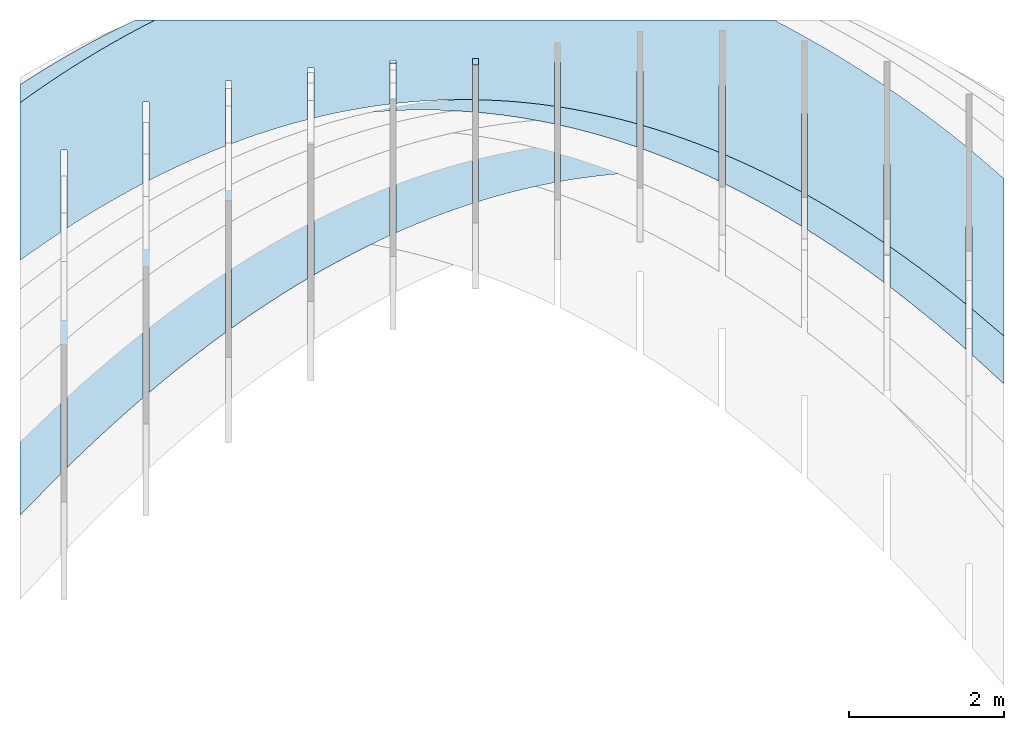
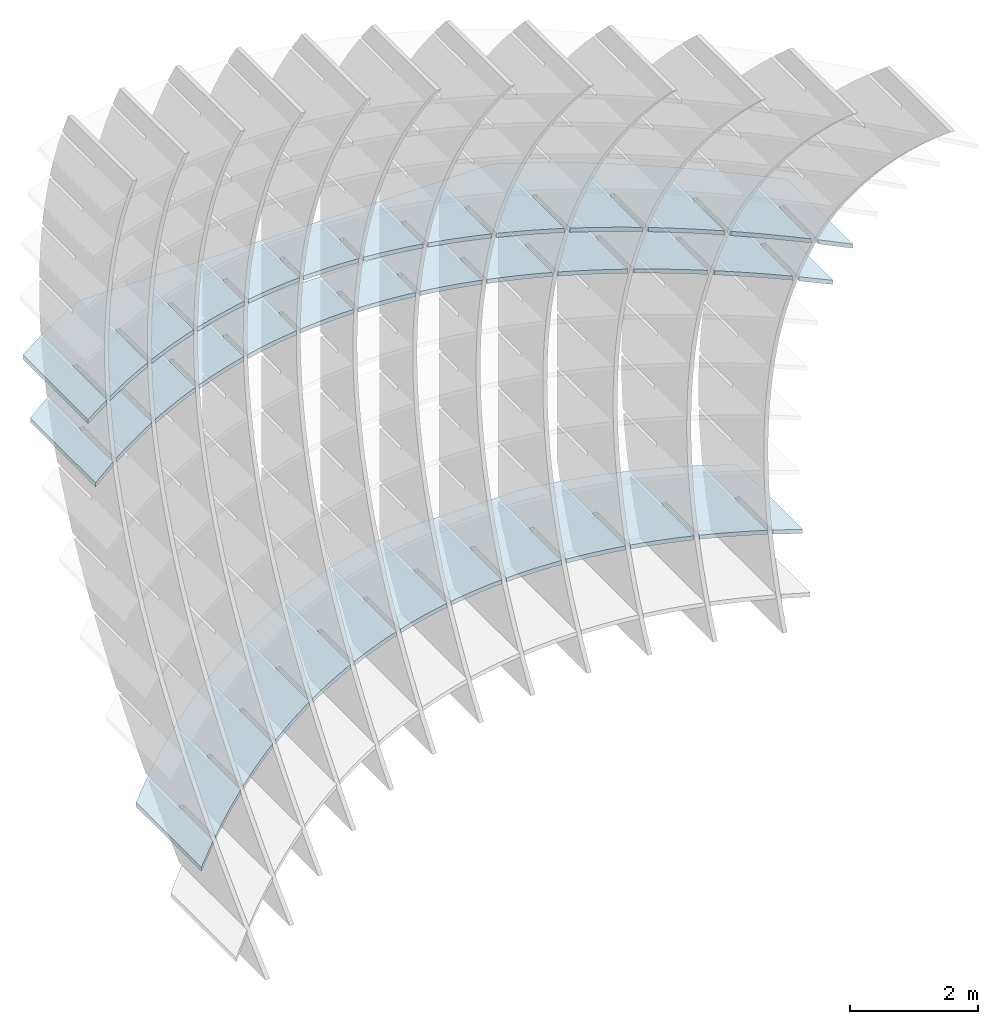
# Not in any storey, part 3 of 9: 3 slabs.
"""IFC2X3 building model written with IfcOpenShell, lengths in metres."""

from ifc_helpers import new_model, si_unit, point, direction, frame, frame_2d, origin_with_axes, place, context, project, spatial, polyline, circle_curve, parameter, trimmed, segment, composite_curve, outline, extrude, material, layer, layer_set, layer_usage, type_object, element, save


model = new_model("IFC2X3")

# Units and contexts
model_context = context("Model", 3, precision=2.54e-06, world=origin_with_axes(), true_north=direction((0.0, 1.0)), identifier="Body")
ifc_project = project(units=[si_unit("LENGTHUNIT", "METRE"), si_unit("AREAUNIT", "SQUARE_METRE"), si_unit("VOLUMEUNIT", "CUBIC_METRE"), si_unit("PLANEANGLEUNIT", "RADIAN")], contexts=[model_context])

# Building
building_placement = place(None, origin_with_axes())
building = spatial("IfcBuilding", under=ifc_project, at=building_placement, Name="Building", CompositionType="ELEMENT")

# Slabs
ifc_material = material(Name="MATERIAL")
ifc_layer = layer(ifc_material, 0.07874, ventilated=True)
ifc_layer_set = layer_set([ifc_layer], Name="SLAB")
ifc_layer_usage_1 = layer_usage(ifc_layer_set, "AXIS3", "NEGATIVE", -0.07874)
slab_type = type_object("IfcSlabType", Name="SLAB", PredefinedType="FLOOR", material=ifc_material)
slab_1_placement = place(None, frame((6.71456553163902, -0.108020556444148, 1.44983825891174), z_axis=(0.0, 0.0, 1.0), x_axis=(-0.85002223, -0.52674681, 0.0)))
element("IfcSlab", 1, at=slab_1_placement, inside=building, type_object=slab_type, material=ifc_layer_usage_1, PredefinedType="FLOOR", context=model_context, shape_type="SweptSolid", body=[
    extrude(outline(composite_curve([segment(polyline([(0.0, 0.0), (0.619943851972478, 0.0)]), True, "CONTINUOUS"), segment(polyline([(0.619943851972478, 0.0), (-0.45040566483358, -1.72724518001152)]), True, "CONTINUOUS"), segment(trimmed(circle_curve(frame_2d((-0.780572223311812, 10.3688137838267), x_axis=(-0.11368899, -0.99351639)), 12.1005641361463), [parameter(0.141223936628406), point((-0.45040566483358, -1.72724518001152))], [parameter(0.0), point((-2.15627308445549, -1.65329499764907))], False, "PARAMETER"), True, "CONTINUOUS"), segment(polyline([(-2.15627308445549, -1.65329499764907), (-8.47655792243422, 2.26329652085337)]), True, "CONTINUOUS"), segment(trimmed(circle_curve(frame_2d((1.82307330734841, 8.92364200892579), x_axis=(-0.91794493, -0.39670784)), 12.2655046977285), [parameter(0.166095085931435), point((-8.47655792243422, 2.26329652085337))], [parameter(0.0), point((-9.43598450566048, 4.05782012014648))], False, "PARAMETER"), True, "CONTINUOUS"), segment(trimmed(circle_curve(frame_2d((6.27845292191441, 10.8391995223138), x_axis=(-0.96759334, -0.25251363)), 17.115216921246), [parameter(0.152118271695288), point((-9.43598450566048, 4.05782012014648))], [parameter(0.0), point((-10.2821169341494, 6.51737394696515))], False, "PARAMETER"), True, "CONTINUOUS"), segment(polyline([(-10.2821169341494, 6.51737394696515), (-9.21176741734327, 8.2446191269766)]), True, "CONTINUOUS"), segment(polyline([(-9.21176741734327, 8.2446191269766), (-9.06056282598788, 7.70970050535006)]), True, "CONTINUOUS"), segment(polyline([(-9.06056282598788, 7.70970050535006), (-9.62423124892391, 6.80009709884209)]), True, "CONTINUOUS"), segment(polyline([(-9.62423124892391, 6.80009709884209), (-9.55730049819846, 6.75862105506585)]), True, "CONTINUOUS"), segment(polyline([(-9.55730049819846, 6.75862105506585), (-9.03044741616067, 7.60881478359619)]), True, "CONTINUOUS"), segment(trimmed(circle_curve(frame_2d((7.26166612219884, 12.4941266221262), x_axis=(-0.95786385, -0.28722263)), 17.0087987614199), [parameter(0.0), point((-9.03044741616067, 7.60881478359619))], [parameter(0.0748195872683051), point((-8.61969121322019, 6.40465008541053))], True, "PARAMETER"), True, "CONTINUOUS"), segment(polyline([(-8.61969121322019, 6.40465008541053), (-9.18057947132105, 5.49953308846976)]), True, "CONTINUOUS"), segment(polyline([(-9.18057947132105, 5.49953308846976), (-9.1136487205956, 5.45805704469352)]), True, "CONTINUOUS"), segment(polyline([(-9.1136487205956, 5.45805704469352), (-8.58401554786144, 6.31273706315057)]), True, "CONTINUOUS"), segment(trimmed(circle_curve(frame_2d((4.61745272777462, 11.4666730631361), x_axis=(-0.93152639, -0.36367374)), 14.1718672349332), [parameter(0.0), point((-8.58401554786144, 6.31273706315057))], [parameter(0.0842035553852768), point((-8.10377533227857, 5.22070015503865))], True, "PARAMETER"), True, "CONTINUOUS"), segment(polyline([(-8.10377533227857, 5.22070015503865), (-8.6618884659955, 4.32006143378192)]), True, "CONTINUOUS"), segment(polyline([(-8.6618884659955, 4.32006143378192), (-8.59495771527005, 4.27858539000569)]), True, "CONTINUOUS"), segment(polyline([(-8.59495771527005, 4.27858539000569), (-8.06254941815232, 5.13774368414764)]), True, "CONTINUOUS"), segment(trimmed(circle_curve(frame_2d((2.53365823412119, 10.4346601334395), x_axis=(-0.89446728, -0.44713341)), 11.8463893436303), [parameter(0.0), point((-8.06254941815232, 5.13774368414764))], [parameter(0.094893498567618), point((-7.5129880604681, 4.15757173894531))], True, "PARAMETER"), True, "CONTINUOUS"), segment(polyline([(-7.5129880604681, 4.15757173894531), (-8.06832607016689, 3.26141129278416)]), True, "CONTINUOUS"), segment(polyline([(-8.06832607016689, 3.26141129278416), (-8.00139531944145, 3.21993524900793)]), True, "CONTINUOUS"), segment(polyline([(-8.00139531944145, 3.21993524900793), (-7.46621189757592, 4.08357181942253)]), True, "CONTINUOUS"), segment(trimmed(circle_curve(frame_2d((1.07524938924406, 9.51675930543096), x_axis=(-0.84376384, -0.53671462)), 10.1230473263915), [parameter(0.0), point((-7.46621189757592, 4.08357181942253))], [parameter(0.105381578815588), point((-6.84732939741331, 3.21526483653157))], True, "PARAMETER"), True, "CONTINUOUS"), segment(polyline([(-6.84732939741331, 3.21526483653157), (-7.3001856311673, 2.48448135439944)]), True, "CONTINUOUS"), segment(polyline([(-7.3001856311673, 2.48448135439944), (-7.23325488044185, 2.4430053106232)]), True, "CONTINUOUS"), segment(polyline([(-7.23325488044185, 2.4430053106232), (-6.79500298575276, 3.15022146838022)]), True, "CONTINUOUS"), segment(trimmed(circle_curve(frame_2d((0.145217501277417, 8.77308549960715), x_axis=(-0.77699349, -0.62950864)), 8.93214757615765), [parameter(0.0), point((-6.79500298575276, 3.15022146838022))], [parameter(0.114554431580325), point((-6.10679934349017, 2.3937794483974))], True, "PARAMETER"), True, "CONTINUOUS"), segment(polyline([(-6.10679934349017, 2.3937794483974), (-6.47709396087449, 1.79622735628225)]), True, "CONTINUOUS"), segment(polyline([(-6.47709396087449, 1.79622735628225), (-6.41016321014904, 1.75475131250601)]), True, "CONTINUOUS"), segment(polyline([(-6.41016321014904, 1.75475131250601), (-6.04892268306232, 2.33769263161573)]), True, "CONTINUOUS"), segment(trimmed(circle_curve(frame_2d((-0.353446121629419, 8.26375363661473), x_axis=(-0.6929406, -0.72099468)), 8.21928538845084), [parameter(0.0), point((-6.04892268306232, 2.33769263161573))], [parameter(0.121087811880618), point((-5.29139789857281, 1.69311557434231))], True, "PARAMETER"), True, "CONTINUOUS"), segment(polyline([(-5.29139789857281, 1.69311557434231), (-5.6165665950848, 1.1683841152048)]), True, "CONTINUOUS"), segment(polyline([(-5.6165665950848, 1.1683841152048), (-5.54963584435935, 1.12690807142857)]), True, "CONTINUOUS"), segment(polyline([(-5.54963584435935, 1.12690807142857), (-5.22797098937811, 1.64598530893072)]), True, "CONTINUOUS"), segment(trimmed(circle_curve(frame_2d((-0.517750171626338, 8.0488786368442), x_axis=(-0.59257098, -0.80551824)), 7.94878752519031), [parameter(0.0), point((-5.22797098937811, 1.64598530893072))], [parameter(0.123820419877384), point((-4.40112506266206, 1.11327321436705))], True, "PARAMETER"), True, "CONTINUOUS"), segment(polyline([(-4.40112506266206, 1.11327321436705), (-4.71860353379821, 0.600951631167097)]), True, "CONTINUOUS"), segment(polyline([(-4.71860353379821, 0.600951631167097), (-4.65167278307277, 0.559475587390863)]), True, "CONTINUOUS"), segment(polyline([(-4.65167278307277, 0.559475587390863), (-4.33214790470012, 1.0750995003252)]), True, "CONTINUOUS"), segment(trimmed(circle_curve(frame_2d((-0.444703340745303, 8.1885754207733), x_axis=(-0.47955236, -0.87751327)), 8.10640271073531), [parameter(0.0), point((-4.33214790470012, 1.0750995003252))], [parameter(0.122209681178168), point((-3.43598083575751, 0.654252368471235))], True, "PARAMETER"), True, "CONTINUOUS"), segment(polyline([(-3.43598083575751, 0.654252368471235), (-3.78320477701475, 0.0939299041691344)]), True, "CONTINUOUS"), segment(polyline([(-3.78320477701475, 0.0939299041691344), (-3.7162740262893, 0.0524538603928997)]), True, "CONTINUOUS"), segment(polyline([(-3.7162740262893, 0.0524538603928997), (-3.36145342902837, 0.625035205799166)]), True, "CONTINUOUS"), segment(trimmed(circle_curve(frame_2d((-0.231314321018002, 8.74295890888007), x_axis=(-0.35976601, -0.93304256)), 8.70048596829733), [parameter(0.0), point((-3.36145342902837, 0.625035205799166))], [parameter(0.116579560971218), point((-2.39596521785895, 0.316053036654818))], True, "PARAMETER"), True, "CONTINUOUS"), segment(polyline([(-2.39596521785895, 0.316053036654818), (-2.8103703247344, -0.352681065789085)]), True, "CONTINUOUS"), segment(polyline([(-2.8103703247344, -0.352681065789085), (-2.74343957400895, -0.39415710956532)]), True, "CONTINUOUS"), segment(polyline([(-2.74343957400895, -0.39415710956532), (-2.31588756236284, 0.295792425352612)]), True, "CONTINUOUS"), segment(trimmed(circle_curve(frame_2d((0.0254081955237848, 9.77214402164274), x_axis=(-0.239855, -0.97080872)), 9.76129629723473), [parameter(0.0), point((-2.31588756236284, 0.295792425352612))], [parameter(0.107970086288465), point((-1.28107820896716, 0.0986752189180085))], True, "PARAMETER"), True, "CONTINUOUS"), segment(polyline([(-1.28107820896716, 0.0986752189180085), (-1.80010017695716, -0.738881278707563)]), True, "CONTINUOUS"), segment(polyline([(-1.80010017695716, -0.738881278707563), (-1.73316942623171, -0.780357322483799)]), True, "CONTINUOUS"), segment(polyline([(-1.73316942623171, -0.780357322483799), (-1.19545030470354, 0.0873711589855444)]), True, "CONTINUOUS"), segment(trimmed(circle_curve(frame_2d((0.22369431064194, 11.289366152602), x_axis=(-0.12568222, -0.99207055)), 11.2915305993595), [parameter(0.0), point((-1.19545030470354, 0.0873711589855444))], [parameter(0.0981196132915255), point((-0.0912517868518765, 0.00222868414058078))], True, "PARAMETER"), True, "CONTINUOUS"), segment(polyline([(-0.0912517868518765, 0.00222868414058078), (-0.624350236750215, -0.858043323835378)]), True, "CONTINUOUS"), segment(polyline([(-0.624350236750215, -0.858043323835378), (-0.557419486024768, -0.899519367611613)]), True, "CONTINUOUS"), segment(polyline([(-0.557419486024768, -0.899519367611613), (0.0, 0.0)]), True, "CONTINUOUS")], self_intersect="UNKNOWN")), origin_with_axes(), (0.0, 0.0, 1.0), 0.07874),
])
ifc_layer_usage_2 = layer_usage(ifc_layer_set, "AXIS3", "NEGATIVE", -0.07874)
slab_2_placement = place(None, frame((6.71456553163902, -0.305201526189746, 0.38765644072992), z_axis=(0.0, 0.0, 1.0), x_axis=(-0.82439006, -0.5660221, 0.0)))
element("IfcSlab", 2, at=slab_2_placement, inside=building, type_object=slab_type, material=ifc_layer_usage_2, PredefinedType="FLOOR", context=model_context, shape_type="SweptSolid", body=[
    extrude(outline(composite_curve([segment(polyline([(0.0, 0.0), (0.639219322500902, 0.0)]), True, "CONTINUOUS"), segment(polyline([(0.639219322500902, 0.0), (-0.51093759320319, -1.6751606099888)]), True, "CONTINUOUS"), segment(trimmed(circle_curve(frame_2d((-0.860880402843568, 11.1969275062184), x_axis=(-0.13147961, -0.99131887)), 12.8768440404247), [parameter(0.159040880589641), point((-0.51093759320319, -1.6751606099888))], [parameter(0.0), point((-2.55392287277681, -1.56813103796478))], False, "PARAMETER"), True, "CONTINUOUS"), segment(polyline([(-2.55392287277681, -1.56813103796478), (-9.13748298390622, 2.9521084821252)]), True, "CONTINUOUS"), segment(trimmed(circle_curve(frame_2d((3.3894060369244, 9.67536672278256), x_axis=(-0.97176513, -0.23595028)), 14.2170724803236), [parameter(0.254383189270301), point((-9.13748298390622, 2.9521084821252))], [parameter(0.0), point((-10.4262492228901, 6.32084445385438))], False, "PARAMETER"), True, "CONTINUOUS"), segment(polyline([(-10.4262492228901, 6.32084445385438), (-9.27609230718604, 7.99600506384352)]), True, "CONTINUOUS"), segment(polyline([(-9.27609230718604, 7.99600506384352), (-9.1345958273157, 7.47721675580939)]), True, "CONTINUOUS"), segment(polyline([(-9.1345958273157, 7.47721675580939), (-9.7388014726668, 6.59721378960071)]), True, "CONTINUOUS"), segment(polyline([(-9.7388014726668, 6.59721378960071), (-9.67388899902974, 6.55264520911718)]), True, "CONTINUOUS"), segment(polyline([(-9.67388899902974, 6.55264520911718), (-9.10626167676065, 7.37937321330129)]), True, "CONTINUOUS"), segment(trimmed(circle_curve(frame_2d((5.70841080382251, 11.6910937403307), x_axis=(-0.96016056, -0.27944891)), 15.4293698708066), [parameter(0.0), point((-9.10626167676065, 7.37937321330129))], [parameter(0.0798428635516468), point((-8.71517139560407, 6.21151974716851))], True, "PARAMETER"), True, "CONTINUOUS"), segment(polyline([(-8.71517139560407, 6.21151974716851), (-9.31638958147367, 5.33586790416582)]), True, "CONTINUOUS"), segment(polyline([(-9.31638958147367, 5.33586790416582), (-9.2514771078366, 5.29129932368229)]), True, "CONTINUOUS"), segment(polyline([(-9.2514771078366, 5.29129932368229), (-8.68086240575325, 6.12237833504081)]), True, "CONTINUOUS"), segment(trimmed(circle_curve(frame_2d((3.37531212291804, 10.7922639768272), x_axis=(-0.9324905, -0.3611945)), 12.9290052275163), [parameter(0.0), point((-8.68086240575325, 6.12237833504081))], [parameter(0.0895181356163792), point((-8.2151072451179, 5.06327147847268))], True, "PARAMETER"), True, "CONTINUOUS"), segment(polyline([(-8.2151072451179, 5.06327147847268), (-8.81334338778476, 4.19196287007089)]), True, "CONTINUOUS"), segment(polyline([(-8.81334338778476, 4.19196287007089), (-8.7484309141477, 4.14739428958736)]), True, "CONTINUOUS"), segment(polyline([(-8.7484309141477, 4.14739428958736), (-8.17483416886108, 4.9828165355456)]), True, "CONTINUOUS"), segment(trimmed(circle_curve(frame_2d((1.57220634854681, 9.8933455085617), x_axis=(-0.89306672, -0.44992426)), 10.9141235856491), [parameter(0.0), point((-8.17483416886108, 4.9828165355456))], [parameter(0.100224490194485), point((-7.63458914310767, 4.0322013866626))], True, "PARAMETER"), True, "CONTINUOUS"), segment(polyline([(-7.63458914310767, 4.0322013866626), (-8.14281575209515, 3.2919883038217)]), True, "CONTINUOUS"), segment(polyline([(-8.14281575209515, 3.2919883038217), (-8.07790327845808, 3.24741972333816)]), True, "CONTINUOUS"), segment(polyline([(-8.07790327845808, 3.24741972333816), (-7.58835198044396, 3.96043291293423)]), True, "CONTINUOUS"), segment(trimmed(circle_curve(frame_2d((0.352107047136366, 9.11139008078399), x_axis=(-0.83894252, -0.54422004)), 9.46484280448993), [parameter(0.0), point((-7.58835198044396, 3.96043291293423))], [parameter(0.110213642371295), point((-6.97361708957169, 3.11830947173511))], True, "PARAMETER"), True, "CONTINUOUS"), segment(polyline([(-6.97361708957169, 3.11830947173511), (-7.37301263520595, 2.53660476978088)]), True, "CONTINUOUS"), segment(polyline([(-7.37301263520595, 2.53660476978088), (-7.30810016156888, 2.49203618929734)]), True, "CONTINUOUS"), segment(polyline([(-7.30810016156888, 2.49203618929734), (-6.92141584050189, 3.05522746720671)]), True, "CONTINUOUS"), segment(trimmed(circle_curve(frame_2d((-0.379069204790771, 8.51099490257198), x_axis=(-0.76800116, -0.64044845)), 8.51866760770678), [parameter(0.0), point((-6.92141584050189, 3.05522746720671))], [parameter(0.118233031779908), point((-6.23219108451158, 2.32159573369248))], True, "PARAMETER"), True, "CONTINUOUS"), segment(polyline([(-6.23219108451158, 2.32159573369248), (-6.56298254255427, 1.83981032418197)]), True, "CONTINUOUS"), segment(polyline([(-6.56298254255427, 1.83981032418197), (-6.4980700689172, 1.79524174369844)]), True, "CONTINUOUS"), segment(polyline([(-6.4980700689172, 1.79524174369844), (-6.17402574903486, 2.26720019836303)]), True, "CONTINUOUS"), segment(trimmed(circle_curve(frame_2d((-0.715405830709196, 8.1567571830059), x_axis=(-0.67976508, -0.73342992)), 8.03015646722387), [parameter(0.0), point((-6.17402574903486, 2.26720019836303))], [parameter(0.122982293439983), point((-5.41031112792561, 1.64206017253285))], True, "PARAMETER"), True, "CONTINUOUS"), segment(polyline([(-5.41031112792561, 1.64206017253285), (-5.71272547414011, 1.20160496702499)]), True, "CONTINUOUS"), segment(polyline([(-5.71272547414011, 1.20160496702499), (-5.64781300050304, 1.15703638654146)]), True, "CONTINUOUS"), segment(polyline([(-5.64781300050304, 1.15703638654146), (-5.34618170604288, 1.5963511064032)]), True, "CONTINUOUS"), segment(trimmed(circle_curve(frame_2d((-0.750986254095934, 8.11327413116397), x_axis=(-0.57626583, -0.81726231)), 7.97408972562079), [parameter(0.0), point((-5.34618170604288, 1.5963511064032))], [parameter(0.123558271913986), point((-4.50797721981565, 1.07970278825777))], True, "PARAMETER"), True, "CONTINUOUS"), segment(polyline([(-4.50797721981565, 1.07970278825777), (-4.82224142996347, 0.621988698309929)]), True, "CONTINUOUS"), segment(polyline([(-4.82224142996347, 0.621988698309929), (-4.7573289563264, 0.577420117826396)]), True, "CONTINUOUS"), segment(polyline([(-4.7573289563264, 0.577420117826396), (-4.43788371152595, 1.04268019132721)]), True, "CONTINUOUS"), segment(trimmed(circle_curve(frame_2d((-0.579893898427181, 8.44514295612494), x_axis=(-0.4621738, -0.88678937)), 8.34748706990257), [parameter(0.0), point((-4.43788371152595, 1.04268019132721))], [parameter(0.119844445167166), point((-3.52518936018013, 0.63452358086614))], True, "PARAMETER"), True, "CONTINUOUS"), segment(polyline([(-3.52518936018013, 0.63452358086614), (-3.89153041002436, 0.100961518036794)]), True, "CONTINUOUS"), segment(polyline([(-3.89153041002436, 0.100961518036794), (-3.82661793638729, 0.0563929375532603)]), True, "CONTINUOUS"), segment(polyline([(-3.82661793638729, 0.0563929375532603), (-3.44913176548406, 0.606187453135067)]), True, "CONTINUOUS"), segment(trimmed(circle_curve(frame_2d((-0.296212187178691, 9.2169608669687), x_axis=(-0.34383511, -0.93903004)), 9.16985935833508), [parameter(0.0), point((-3.44913176548406, 0.606187453135067))], [parameter(0.112565458213441), point((-2.46194754902009, 0.306522550358507))], True, "PARAMETER"), True, "CONTINUOUS"), segment(polyline([(-2.46194754902009, 0.306522550358507), (-2.92059241432276, -0.361476573794421)]), True, "CONTINUOUS"), segment(polyline([(-2.92059241432276, -0.361476573794421), (-2.8556799406857, -0.406045154277955)]), True, "CONTINUOUS"), segment(polyline([(-2.8556799406857, -0.406045154277955), (-2.37992586791721, 0.286872891826767)]), True, "CONTINUOUS"), segment(trimmed(circle_curve(frame_2d((0.00597545649898953, 10.4933250744186), x_axis=(-0.22762733, -0.97374833)), 10.4816120556613), [parameter(0.0), point((-2.37992586791721, 0.286872891826767))], [parameter(0.102963694286493), point((-1.31825178385167, 0.0956996964153215))], True, "PARAMETER"), True, "CONTINUOUS"), segment(polyline([(-1.31825178385167, 0.0956996964153215), (-1.89263158413763, -0.740863039915794)]), True, "CONTINUOUS"), segment(polyline([(-1.89263158413763, -0.740863039915794), (-1.82771911050056, -0.785431620399328)]), True, "CONTINUOUS"), segment(polyline([(-1.82771911050056, -0.785431620399328), (-1.2302660163302, 0.0847365071012922)]), True, "CONTINUOUS"), segment(trimmed(circle_curve(frame_2d((0.227700576123366, 12.2878085829216), x_axis=(-0.11863168, -0.99293833)), 12.2898590175956), [parameter(0.0), point((-1.2302660163302, 0.0847365071012922))], [parameter(0.092730266045169), point((-0.0940289780220891, 0.0021614788262917))], True, "PARAMETER"), True, "CONTINUOUS"), segment(polyline([(-0.0940289780220891, 0.0021614788262917), (-0.665385292056546, -0.829997662653379)]), True, "CONTINUOUS"), segment(polyline([(-0.665385292056546, -0.829997662653379), (-0.600472818419479, -0.874566243136913)]), True, "CONTINUOUS"), segment(polyline([(-0.600472818419479, -0.874566243136913), (0.0, 0.0)]), True, "CONTINUOUS")], self_intersect="UNKNOWN")), origin_with_axes(), (0.0, 0.0, 1.0), 0.07874),
])
ifc_layer_usage_3 = layer_usage(ifc_layer_set, "AXIS3", "NEGATIVE", -0.07874)
slab_3_placement = place(None, frame((6.71456553163902, -3.42319496995906, -4.92325265017917), z_axis=(0.0, 0.0, 1.0), x_axis=(-0.6996724, -0.7144638, 0.0)))
element("IfcSlab", 3, at=slab_3_placement, inside=building, type_object=slab_type, material=ifc_layer_usage_3, PredefinedType="FLOOR", context=model_context, shape_type="SweptSolid", body=[
    extrude(outline(composite_curve([segment(polyline([(0.0, 0.0), (0.753161129482883, 0.0)]), True, "CONTINUOUS"), segment(polyline([(0.753161129482883, 0.0), (-0.698629319765602, -1.42173432520668)]), True, "CONTINUOUS"), segment(trimmed(circle_curve(frame_2d((-1.12790886808711, 18.8110326763434), x_axis=(-0.11480144, -0.99338846)), 20.2373205111156), [parameter(0.136268982861436), point((-0.698629319765602, -1.42173432520668))], [parameter(0.0), point((-3.45118248235088, -1.29248794027713))], False, "PARAMETER"), True, "CONTINUOUS"), segment(trimmed(circle_curve(frame_2d((-1.80699979804032, 12.8984882623517), x_axis=(-0.26255508, -0.96491701)), 14.2859071214594), [parameter(0.15032238882636), point((-3.45118248235088, -1.29248794027713))], [parameter(0.0), point((-5.55783729767384, -0.886226472974065))], False, "PARAMETER"), True, "CONTINUOUS"), segment(trimmed(circle_curve(frame_2d((-3.13709164146096, 8.40109302342931), x_axis=(-0.60364718, -0.79725158)), 9.59762017170651), [parameter(0.393090525130409), point((-5.55783729767384, -0.886226472974065))], [parameter(0.0), point((-8.93066796749937, 0.749375156524194))], False, "PARAMETER"), True, "CONTINUOUS"), segment(polyline([(-8.93066796749937, 0.749375156524194), (-10.4452230504127, 2.29594863741314)]), True, "CONTINUOUS"), segment(trimmed(circle_curve(frame_2d((-2.84599575259045, 7.83735161751861), x_axis=(-0.96481843, -0.26291711)), 9.40507323267014), [parameter(0.364015219483743), point((-10.4452230504127, 2.29594863741314))], [parameter(0.0), point((-11.9201837019689, 5.36459696506245))], False, "PARAMETER"), True, "CONTINUOUS"), segment(polyline([(-11.9201837019689, 5.36459696506245), (-10.4683932527203, 6.78633129026876)]), True, "CONTINUOUS"), segment(polyline([(-10.4683932527203, 6.78633129026876), (-10.3315963747117, 6.34602775122306)]), True, "CONTINUOUS"), segment(polyline([(-10.3315963747117, 6.34602775122306), (-11.084847273671, 5.60837125327763)]), True, "CONTINUOUS"), segment(polyline([(-11.084847273671, 5.60837125327763), (-11.0297550685693, 5.55211437336926)]), True, "CONTINUOUS"), segment(polyline([(-11.0297550685693, 5.55211437336926), (-10.3038548297345, 6.26298644637497)]), True, "CONTINUOUS"), segment(trimmed(circle_curve(frame_2d((-0.805191645483418, 9.45979317694922), x_axis=(-0.94776378, -0.31897306)), 10.0221841711521), [parameter(0.0), point((-10.3038548297345, 6.26298644637497))], [parameter(0.106455079224624), point((-9.91040907148871, 5.27181142129877))], True, "PARAMETER"), True, "CONTINUOUS"), segment(polyline([(-9.91040907148871, 5.27181142129877), (-10.6598890370358, 4.53784778789304)]), True, "CONTINUOUS"), segment(polyline([(-10.6598890370358, 4.53784778789304), (-10.604796831934, 4.48159090798466)]), True, "CONTINUOUS"), segment(polyline([(-10.604796831934, 4.48159090798466), (-9.87512576024723, 5.19615574705245)]), True, "CONTINUOUS"), segment(trimmed(circle_curve(frame_2d((-1.79311143997881, 8.9993524089713), x_axis=(-0.9048232, -0.42578749)), 8.9321475761574), [parameter(0.0), point((-9.87512576024723, 5.19615574705245))], [parameter(0.114554431580327), point((-9.38743394092832, 4.29727562590762))], True, "PARAMETER"), True, "CONTINUOUS"), segment(polyline([(-9.38743394092832, 4.29727562590762), (-10.1331498097836, 3.56699816186205)]), True, "CONTINUOUS"), segment(polyline([(-10.1331498097836, 3.56699816186205), (-10.0780576046819, 3.51074128195367)]), True, "CONTINUOUS"), segment(polyline([(-10.0780576046819, 3.51074128195367), (-9.34462243630305, 4.228992290381)]), True, "CONTINUOUS"), segment(trimmed(circle_curve(frame_2d((-2.39896105830458, 8.62381200442849), x_axis=(-0.84504444, -0.53469608)), 8.21928538845075), [parameter(0.0), point((-9.34462243630305, 4.228992290381))], [parameter(0.121087811880619), point((-8.76290546852986, 3.4221907340588))], True, "PARAMETER"), True, "CONTINUOUS"), segment(polyline([(-8.76290546852986, 3.4221907340588), (-9.48861461013444, 2.71150580203614)]), True, "CONTINUOUS"), segment(polyline([(-9.48861461013444, 2.71150580203614), (-9.43352240503268, 2.65524892212777)]), True, "CONTINUOUS"), segment(polyline([(-9.43352240503268, 2.65524892212777), (-8.71256577052052, 3.36127973725127)]), True, "CONTINUOUS"), segment(trimmed(circle_curve(frame_2d((-2.6098167460523, 8.45438070473375), x_axis=(-0.76775848, -0.64073935)), 7.94878752519016), [parameter(0.0), point((-8.71256577052052, 3.36127973725127))], [parameter(0.123820419877386), point((-8.03682365429317, 2.64655674575182))], True, "PARAMETER"), True, "CONTINUOUS"), segment(polyline([(-8.03682365429317, 2.64655674575182), (-8.75210200149102, 1.9460866615088)]), True, "CONTINUOUS"), segment(polyline([(-8.75210200149102, 1.9460866615088), (-8.69700979638926, 1.88982978160042)]), True, "CONTINUOUS"), segment(polyline([(-8.69700979638926, 1.88982978160042), (-7.97895576289965, 2.59301808766328)]), True, "CONTINUOUS"), segment(trimmed(circle_curve(frame_2d((-2.50552853777762, 8.5725966112579), x_axis=(-0.67519804, -0.7376365)), 8.10640271073064), [parameter(0.0), point((-7.97895576289965, 2.59301808766328))], [parameter(0.122209681175241), point((-7.20918849823822, 1.97037366100086))], True, "PARAMETER"), True, "CONTINUOUS"), segment(polyline([(-7.20918849823822, 1.97037366100086), (-7.94361207711346, 1.25115470493905)]), True, "CONTINUOUS"), segment(polyline([(-7.94361207711346, 1.25115470493905), (-7.8885198720117, 1.19489782503067)]), True, "CONTINUOUS"), segment(polyline([(-7.8885198720117, 1.19489782503067), (-7.1437924134604, 1.92420734163096)]), True, "CONTINUOUS"), segment(trimmed(circle_curve(frame_2d((-2.16594646802886, 9.05999782537804), x_axis=(-0.57213424, -0.82015999)), 8.70048596828847), [parameter(0.0), point((-7.1437924134604, 1.92420734163096))], [parameter(0.116579560974134), point((-6.28000000030419, 1.39364147976264))], True, "PARAMETER"), True, "CONTINUOUS"), segment(polyline([(-6.28000000030419, 1.39364147976264), (-7.01065948239167, 0.678108693155389)]), True, "CONTINUOUS"), segment(polyline([(-7.01065948239167, 0.678108693155389), (-6.95556727728991, 0.62185181324701)]), True, "CONTINUOUS"), segment(polyline([(-6.95556727728991, 0.62185181324701), (-6.2070757221429, 1.35484749911248)]), True, "CONTINUOUS"), segment(trimmed(circle_curve(frame_2d((-1.67092057135428, 9.99812244848063), x_axis=(-0.46470827, -0.88546384)), 9.76129629723435), [parameter(0.0), point((-6.2070757221429, 1.35484749911248))], [parameter(0.107970086288469), point((-5.24925816055244, 0.916360202080844))], True, "PARAMETER"), True, "CONTINUOUS"), segment(polyline([(-5.24925816055244, 0.916360202080844), (-5.97615354594783, 0.204513584833048)]), True, "CONTINUOUS"), segment(polyline([(-5.97615354594783, 0.204513584833048), (-5.92106134084607, 0.148256704924669)]), True, "CONTINUOUS"), segment(polyline([(-5.92106134084607, 0.148256704924669), (-5.16880568900701, 0.884938560149679)]), True, "CONTINUOUS"), segment(trimmed(circle_curve(frame_2d((-1.10030088231684, 11.4685085819214), x_axis=(-0.35881781, -0.93340762)), 11.3386368566863), [parameter(0.0), point((-5.16880568900701, 0.884938560149679))], [parameter(0.0977064081270845), point((-4.11696297896168, 0.538529827940567))], True, "PARAMETER"), True, "CONTINUOUS"), segment(polyline([(-4.11696297896168, 0.538529827940567), (-4.84009426766565, -0.169630619947564)]), True, "CONTINUOUS"), segment(polyline([(-4.84009426766565, -0.169630619947564), (-4.78500206256389, -0.225887499855942)]), True, "CONTINUOUS"), segment(polyline([(-4.78500206256389, -0.225887499855942), (-4.02898231403277, 0.514480524728604)]), True, "CONTINUOUS"), segment(trimmed(circle_curve(frame_2d((-0.533937435465276, 13.5526943270814), x_axis=(-0.25892037, -0.96589867)), 13.4985316927088), [parameter(0.0), point((-4.02898231403277, 0.514480524728604))], [parameter(0.086981569413015), point((-2.88311445553475, 0.260150357342525))], True, "PARAMETER"), True, "CONTINUOUS"), segment(polyline([(-2.88311445553475, 0.260150357342525), (-3.60248164754513, -0.444323921186442)]), True, "CONTINUOUS"), segment(polyline([(-3.60248164754513, -0.444323921186442), (-3.54738944244338, -0.500580801094821)]), True, "CONTINUOUS"), segment(polyline([(-3.54738944244338, -0.500580801094821), (-2.78760559722021, 0.243473392849257)]), True, "CONTINUOUS"), segment(trimmed(circle_curve(frame_2d((-0.0516802653524629, 16.3322177853338), x_axis=(-0.16764545, -0.98584735)), 16.3197115032178), [parameter(0.0), point((-2.78760559722021, 0.243473392849257))], [parameter(0.0766416805148208), point((-1.54771259026579, 0.08122179028559))], True, "PARAMETER"), True, "CONTINUOUS"), segment(polyline([(-1.54771259026579, 0.08122179028559), (-2.26331568558628, -0.619566318883593)]), True, "CONTINUOUS"), segment(polyline([(-2.26331568558628, -0.619566318883593), (-2.20822348048452, -0.675823198791972)]), True, "CONTINUOUS"), segment(polyline([(-2.20822348048452, -0.675823198791972), (-1.4446755385693, 0.071917164511644)]), True, "CONTINUOUS"), segment(trimmed(circle_curve(frame_2d((0.260922685650228, 19.8062940794665), x_axis=(-0.08610677, -0.99628591)), 19.8079453130294), [parameter(0.0), point((-1.4446755385693, 0.071917164511644))], [parameter(0.0674528993509093), point((-0.110665119821559, 0.00183448000283609))], True, "PARAMETER"), True, "CONTINUOUS"), segment(polyline([(-0.110665119821559, 0.00183448000283609), (-0.822451810881098, -0.695216235153299)]), True, "CONTINUOUS"), segment(polyline([(-0.822451810881098, -0.695216235153299), (-0.767359605779338, -0.751473115061678)]), True, "CONTINUOUS"), segment(polyline([(-0.767359605779338, -0.751473115061678), (0.0, 0.0)]), True, "CONTINUOUS")], self_intersect="UNKNOWN")), origin_with_axes(), (0.0, 0.0, 1.0), 0.07874),
])

save(model, "model.ifc")
